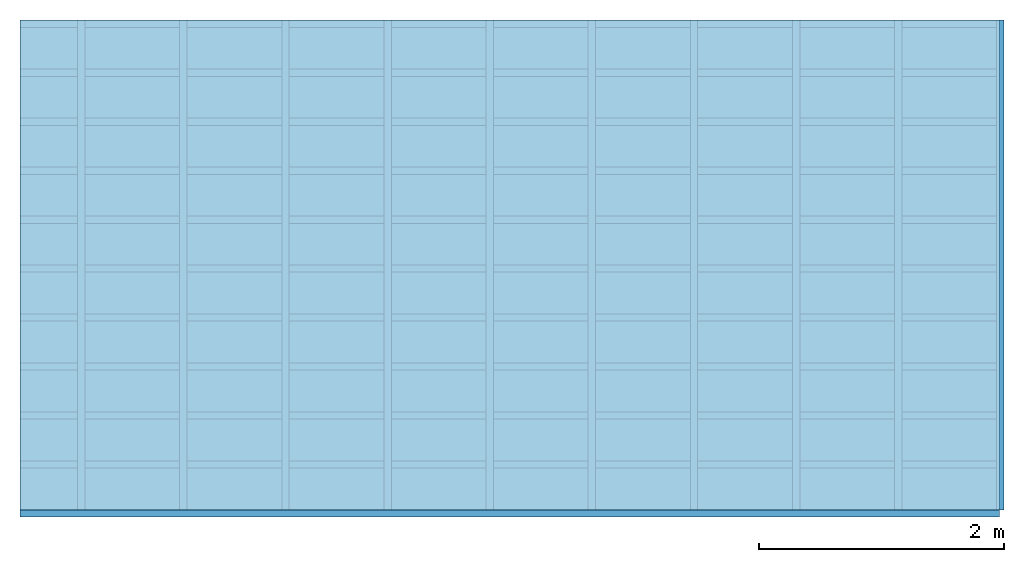
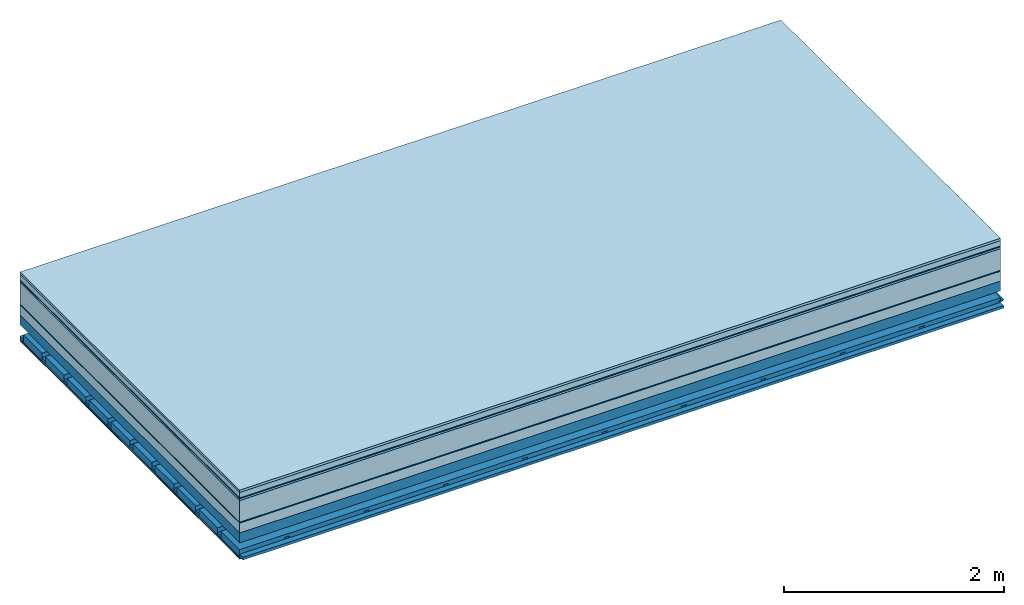
# One storey: 10 plates, 4 members, 1 element without a shape of its own.
"""IFC4 building model written with IfcOpenShell, lengths in metres."""

from ifc_helpers import new_model, si_unit, derived_unit, direction, frame, frame_2d, origin, origin_with_axes, place, context, project, spatial, polyline, rectangle, outline, extrude, material, layer, layer_set, type_object, element, aggregate, save


model = new_model("IFC4")

# Units and contexts
plan_context = context("Plan", 3, precision=1e-05, world=origin(), true_north=direction((0.0, 1.0)))
model_context = context("Model", 3, precision=1e-05, world=origin(), true_north=direction((0.0, 1.0)))
ifc_project = project(units=[si_unit("LENGTHUNIT", "METRE"), derived_unit("SOUNDPRESSUREUNIT", [(si_unit("PRESSUREUNIT", "PASCAL", prefix="MICRO"), 0)]), si_unit("ENERGYUNIT", "JOULE", prefix="MEGA"), si_unit("MASSUNIT", "GRAM", prefix="KILO"), derived_unit("THERMALTRANSMITTANCEUNIT", [(si_unit("POWERUNIT", "WATT"), 1), (si_unit("AREAUNIT", "SQUARE_METRE"), -1), (si_unit("THERMODYNAMICTEMPERATUREUNIT", "KELVIN"), -1)]), derived_unit("AREADENSITYUNIT", [(si_unit("MASSUNIT", "GRAM", prefix="KILO"), 1), (si_unit("AREAUNIT", "SQUARE_METRE"), -1)]), derived_unit("USERDEFINED", [(si_unit("ENERGYUNIT", "JOULE", prefix="MEGA"), 1), (si_unit("AREAUNIT", "SQUARE_METRE"), -1)])], contexts=[plan_context, model_context])

# Site, building, storey
site = spatial("IfcSite", under=ifc_project)
building_placement = place(None, origin())
building = spatial("IfcBuilding", under=site, at=building_placement)
storey_placement = place(building_placement, origin())
storey = spatial("IfcBuildingStorey", under=building, at=storey_placement)

# Slab, members, plates
ifc_material_1 = material(Category="07.009")
ifc_layer_1 = layer(ifc_material_1, 0.026, Name="Use and protection layer 3")
ifc_material_2 = material(Category="07.011")
ifc_layer_2 = layer(ifc_material_2, 0.06, Name="Use and protection layer 2")
ifc_material_3 = material(Name="Protective layer + Fire protection cover RF1", Category="09.007")
ifc_layer_3 = layer(ifc_material_3, 0.01, Name="Use and protection layer 1")
ifc_material_4 = material(Name="Bituminous", Category="09.003")
ifc_layer_4 = layer(ifc_material_4, 0.02, Name="Seal")
ifc_material_5 = material(Name="Mineral wool", Category="10.008")
ifc_layer_5 = layer(ifc_material_5, 0.24, Name="Exterior insulation layer 1")
ifc_material_6 = material(Name="Vapor-permeable barrier", Category="09.006")
ifc_layer_6 = layer(ifc_material_6, 0.01, Name="layer / temporary roof")
ifc_material_7 = material(Category="01.002")
ifc_layer_7 = layer(ifc_material_7, 0.11, Name="above 1st layer")
ifc_material_8 = material(Name="Rigid, of the art")
ifc_layer_8 = layer(ifc_material_8, 0.0, Name="Bond")
ifc_layer_9 = layer(None, 0.11, Name="Support")
ifc_material_9 = material(Name="no composite action")
ifc_layer_10 = layer(ifc_material_9, 0.0, Name="Bond")
ifc_layer_11 = layer(None, 0.125, Name="Coupling")
ifc_layer_12 = layer(None, 0.03, Name="Battens / profiles")
ifc_material_10 = material(Name="Plasterboard type A", Category="03.008")
ifc_layer_13 = layer(ifc_material_10, 0.0125, Name="Covering below 1st layer")
ifc_layer_14 = layer(ifc_material_10, 0.0125, Name="Covering below 2nd layer")
ifc_material_11 = material(Category="04.001")
ifc_layer_15 = layer(ifc_material_11, 0.003, Name="Surface below")
ifc_layer_set = layer_set([ifc_layer_1, ifc_layer_2, ifc_layer_3, ifc_layer_4, ifc_layer_5, ifc_layer_6, ifc_layer_7, ifc_layer_8, ifc_layer_9, ifc_layer_10, ifc_layer_11, ifc_layer_12, ifc_layer_13, ifc_layer_14, ifc_layer_15])
slab_type = type_object("IfcSlabType", Name="F0090", PredefinedType="NOTDEFINED", material=ifc_layer_set)
slab_placement = place(None, frame((0.0, 0.0, 0.0), z_axis=(0.0, 0.0, -1.0), x_axis=(1.0, 0.0, 0.0)))
slab = element("IfcSlab", 1, at=slab_placement, inside=storey, type_object=slab_type, material=ifc_layer_set, Name="Slab #1")
ifc_material_12 = material(Name="Solid timber panel")
member_1_placement = place(slab_placement, origin())
member_1 = element("IfcMember", 2, at=member_1_placement, material=ifc_material_12, Name="Support", context=plan_context, shape_type="SweptSolid", body=[
    extrude(rectangle(XDim=1.0, YDim=0.11, at=frame_2d((0.5, 0.055), x_axis=(1.0, 0.0))), frame((0.0, 4.0, 0.476), z_axis=(0.0, -1.0, 0.0), x_axis=(1.0, 0.0, 0.0)), (0.0, 0.0, 1.0), 4.0),
    extrude(rectangle(XDim=1.0, YDim=0.11, at=frame_2d((0.5, 0.055), x_axis=(1.0, 0.0))), frame((1.0, 4.0, 0.476), z_axis=(0.0, -1.0, 0.0), x_axis=(1.0, 0.0, 0.0)), (0.0, 0.0, 1.0), 4.0),
    extrude(rectangle(XDim=1.0, YDim=0.11, at=frame_2d((0.5, 0.055), x_axis=(1.0, 0.0))), frame((2.0, 4.0, 0.476), z_axis=(0.0, -1.0, 0.0), x_axis=(1.0, 0.0, 0.0)), (0.0, 0.0, 1.0), 4.0),
    extrude(rectangle(XDim=1.0, YDim=0.11, at=frame_2d((0.5, 0.055), x_axis=(1.0, 0.0))), frame((3.0, 4.0, 0.476), z_axis=(0.0, -1.0, 0.0), x_axis=(1.0, 0.0, 0.0)), (0.0, 0.0, 1.0), 4.0),
    extrude(rectangle(XDim=1.0, YDim=0.11, at=frame_2d((0.5, 0.055), x_axis=(1.0, 0.0))), frame((4.0, 4.0, 0.476), z_axis=(0.0, -1.0, 0.0), x_axis=(1.0, 0.0, 0.0)), (0.0, 0.0, 1.0), 4.0),
    extrude(rectangle(XDim=1.0, YDim=0.11, at=frame_2d((0.5, 0.055), x_axis=(1.0, 0.0))), frame((5.0, 4.0, 0.476), z_axis=(0.0, -1.0, 0.0), x_axis=(1.0, 0.0, 0.0)), (0.0, 0.0, 1.0), 4.0),
    extrude(rectangle(XDim=1.0, YDim=0.11, at=frame_2d((0.5, 0.055), x_axis=(1.0, 0.0))), frame((6.0, 4.0, 0.476), z_axis=(0.0, -1.0, 0.0), x_axis=(1.0, 0.0, 0.0)), (0.0, 0.0, 1.0), 4.0),
    extrude(rectangle(XDim=1.0, YDim=0.11, at=frame_2d((0.5, 0.055), x_axis=(1.0, 0.0))), frame((7.0, 4.0, 0.476), z_axis=(0.0, -1.0, 0.0), x_axis=(1.0, 0.0, 0.0)), (0.0, 0.0, 1.0), 4.0),
])
ifc_material_13 = material()
member_2_placement = place(slab_placement, origin())
member_2 = element("IfcMember", 3, at=member_2_placement, material=ifc_material_13, Name="Coupling", context=plan_context, shape_type="SweptSolid", body=[
    extrude(outline(polyline([(0.0, 0.0), (0.06, 0.0), (0.04, 0.02), (0.02, 0.02), (0.0, 0.0)])), frame((0.47, 4.0, 0.691), z_axis=(0.0, -1.0, 0.0), x_axis=(1.0, 0.0, 0.0)), (0.0, 0.0, 1.0), 4.0),
    extrude(outline(polyline([(0.0, 0.0), (0.06, 0.0), (0.04, 0.02), (0.02, 0.02), (0.0, 0.0)])), frame((1.304, 4.0, 0.691), z_axis=(0.0, -1.0, 0.0), x_axis=(1.0, 0.0, 0.0)), (0.0, 0.0, 1.0), 4.0),
    extrude(outline(polyline([(0.0, 0.0), (0.06, 0.0), (0.04, 0.02), (0.02, 0.02), (0.0, 0.0)])), frame((2.138, 4.0, 0.691), z_axis=(0.0, -1.0, 0.0), x_axis=(1.0, 0.0, 0.0)), (0.0, 0.0, 1.0), 4.0),
    extrude(outline(polyline([(0.0, 0.0), (0.06, 0.0), (0.04, 0.02), (0.02, 0.02), (0.0, 0.0)])), frame((2.972, 4.0, 0.691), z_axis=(0.0, -1.0, 0.0), x_axis=(1.0, 0.0, 0.0)), (0.0, 0.0, 1.0), 4.0),
    extrude(outline(polyline([(0.0, 0.0), (0.06, 0.0), (0.04, 0.02), (0.02, 0.02), (0.0, 0.0)])), frame((3.806, 4.0, 0.691), z_axis=(0.0, -1.0, 0.0), x_axis=(1.0, 0.0, 0.0)), (0.0, 0.0, 1.0), 4.0),
    extrude(outline(polyline([(0.0, 0.0), (0.06, 0.0), (0.04, 0.02), (0.02, 0.02), (0.0, 0.0)])), frame((4.64, 4.0, 0.691), z_axis=(0.0, -1.0, 0.0), x_axis=(1.0, 0.0, 0.0)), (0.0, 0.0, 1.0), 4.0),
    extrude(outline(polyline([(0.0, 0.0), (0.06, 0.0), (0.04, 0.02), (0.02, 0.02), (0.0, 0.0)])), frame((5.474, 4.0, 0.691), z_axis=(0.0, -1.0, 0.0), x_axis=(1.0, 0.0, 0.0)), (0.0, 0.0, 1.0), 4.0),
    extrude(outline(polyline([(0.0, 0.0), (0.06, 0.0), (0.04, 0.02), (0.02, 0.02), (0.0, 0.0)])), frame((6.308, 4.0, 0.691), z_axis=(0.0, -1.0, 0.0), x_axis=(1.0, 0.0, 0.0)), (0.0, 0.0, 1.0), 4.0),
    extrude(outline(polyline([(0.0, 0.0), (0.06, 0.0), (0.04, 0.02), (0.02, 0.02), (0.0, 0.0)])), frame((7.142, 4.0, 0.691), z_axis=(0.0, -1.0, 0.0), x_axis=(1.0, 0.0, 0.0)), (0.0, 0.0, 1.0), 4.0),
    extrude(outline(polyline([(0.0, 0.0), (0.06, 0.0), (0.04, 0.02), (0.02, 0.02), (0.0, 0.0)])), frame((7.976, 4.0, 0.691), z_axis=(0.0, -1.0, 0.0), x_axis=(1.0, 0.0, 0.0)), (0.0, 0.0, 1.0), 4.0),
])
member_3_placement = place(slab_placement, origin())
member_3 = element("IfcMember", 4, at=member_3_placement, material=ifc_material_13, Name="Battens / profiles", context=plan_context, shape_type="SweptSolid", body=[
    extrude(rectangle(XDim=0.06, YDim=0.03, at=frame_2d((0.03, 0.015), x_axis=(1.0, 0.0))), frame((0.0, 0.0, 0.711), z_axis=(1.0, 0.0, 0.0), x_axis=(0.0, 1.0, 0.0)), (0.0, 0.0, 1.0), 8.0),
    extrude(rectangle(XDim=0.06, YDim=0.03, at=frame_2d((0.03, 0.015), x_axis=(1.0, 0.0))), frame((0.0, 0.4, 0.711), z_axis=(1.0, 0.0, 0.0), x_axis=(0.0, 1.0, 0.0)), (0.0, 0.0, 1.0), 8.0),
    extrude(rectangle(XDim=0.06, YDim=0.03, at=frame_2d((0.03, 0.015), x_axis=(1.0, 0.0))), frame((0.0, 0.8, 0.711), z_axis=(1.0, 0.0, 0.0), x_axis=(0.0, 1.0, 0.0)), (0.0, 0.0, 1.0), 8.0),
    extrude(rectangle(XDim=0.06, YDim=0.03, at=frame_2d((0.03, 0.015), x_axis=(1.0, 0.0))), frame((0.0, 1.2, 0.711), z_axis=(1.0, 0.0, 0.0), x_axis=(0.0, 1.0, 0.0)), (0.0, 0.0, 1.0), 8.0),
    extrude(rectangle(XDim=0.06, YDim=0.03, at=frame_2d((0.03, 0.015), x_axis=(1.0, 0.0))), frame((0.0, 1.6, 0.711), z_axis=(1.0, 0.0, 0.0), x_axis=(0.0, 1.0, 0.0)), (0.0, 0.0, 1.0), 8.0),
    extrude(rectangle(XDim=0.06, YDim=0.03, at=frame_2d((0.03, 0.015), x_axis=(1.0, 0.0))), frame((0.0, 2.0, 0.711), z_axis=(1.0, 0.0, 0.0), x_axis=(0.0, 1.0, 0.0)), (0.0, 0.0, 1.0), 8.0),
    extrude(rectangle(XDim=0.06, YDim=0.03, at=frame_2d((0.03, 0.015), x_axis=(1.0, 0.0))), frame((0.0, 2.4, 0.711), z_axis=(1.0, 0.0, 0.0), x_axis=(0.0, 1.0, 0.0)), (0.0, 0.0, 1.0), 8.0),
    extrude(rectangle(XDim=0.06, YDim=0.03, at=frame_2d((0.03, 0.015), x_axis=(1.0, 0.0))), frame((0.0, 2.8, 0.711), z_axis=(1.0, 0.0, 0.0), x_axis=(0.0, 1.0, 0.0)), (0.0, 0.0, 1.0), 8.0),
    extrude(rectangle(XDim=0.06, YDim=0.03, at=frame_2d((0.03, 0.015), x_axis=(1.0, 0.0))), frame((0.0, 3.2, 0.711), z_axis=(1.0, 0.0, 0.0), x_axis=(0.0, 1.0, 0.0)), (0.0, 0.0, 1.0), 8.0),
    extrude(rectangle(XDim=0.06, YDim=0.03, at=frame_2d((0.03, 0.015), x_axis=(1.0, 0.0))), frame((0.0, 3.6, 0.711), z_axis=(1.0, 0.0, 0.0), x_axis=(0.0, 1.0, 0.0)), (0.0, 0.0, 1.0), 8.0),
    extrude(rectangle(XDim=0.06, YDim=0.03, at=frame_2d((0.03, 0.015), x_axis=(1.0, 0.0))), frame((0.0, 4.0, 0.711), z_axis=(1.0, 0.0, 0.0), x_axis=(0.0, 1.0, 0.0)), (0.0, 0.0, 1.0), 8.0),
])
ifc_material_14 = material()
member_4_placement = place(slab_placement, origin())
member_4 = element("IfcMember", 5, at=member_4_placement, material=ifc_material_14, Name="Cavity", context=plan_context, shape_type="SweptSolid", body=[
    extrude(rectangle(XDim=0.34, YDim=0.08, at=frame_2d((0.17, 0.04), x_axis=(1.0, 0.0))), frame((0.0, 0.06, 0.661), z_axis=(1.0, 0.0, 0.0), x_axis=(0.0, 1.0, 0.0)), (0.0, 0.0, 1.0), 8.0),
    extrude(rectangle(XDim=0.34, YDim=0.08, at=frame_2d((0.17, 0.04), x_axis=(1.0, 0.0))), frame((0.0, 0.46, 0.661), z_axis=(1.0, 0.0, 0.0), x_axis=(0.0, 1.0, 0.0)), (0.0, 0.0, 1.0), 8.0),
    extrude(rectangle(XDim=0.34, YDim=0.08, at=frame_2d((0.17, 0.04), x_axis=(1.0, 0.0))), frame((0.0, 0.86, 0.661), z_axis=(1.0, 0.0, 0.0), x_axis=(0.0, 1.0, 0.0)), (0.0, 0.0, 1.0), 8.0),
    extrude(rectangle(XDim=0.34, YDim=0.08, at=frame_2d((0.17, 0.04), x_axis=(1.0, 0.0))), frame((0.0, 1.26, 0.661), z_axis=(1.0, 0.0, 0.0), x_axis=(0.0, 1.0, 0.0)), (0.0, 0.0, 1.0), 8.0),
    extrude(rectangle(XDim=0.34, YDim=0.08, at=frame_2d((0.17, 0.04), x_axis=(1.0, 0.0))), frame((0.0, 1.66, 0.661), z_axis=(1.0, 0.0, 0.0), x_axis=(0.0, 1.0, 0.0)), (0.0, 0.0, 1.0), 8.0),
    extrude(rectangle(XDim=0.34, YDim=0.08, at=frame_2d((0.17, 0.04), x_axis=(1.0, 0.0))), frame((0.0, 2.06, 0.661), z_axis=(1.0, 0.0, 0.0), x_axis=(0.0, 1.0, 0.0)), (0.0, 0.0, 1.0), 8.0),
    extrude(rectangle(XDim=0.34, YDim=0.08, at=frame_2d((0.17, 0.04), x_axis=(1.0, 0.0))), frame((0.0, 2.46, 0.661), z_axis=(1.0, 0.0, 0.0), x_axis=(0.0, 1.0, 0.0)), (0.0, 0.0, 1.0), 8.0),
    extrude(rectangle(XDim=0.34, YDim=0.08, at=frame_2d((0.17, 0.04), x_axis=(1.0, 0.0))), frame((0.0, 2.86, 0.661), z_axis=(1.0, 0.0, 0.0), x_axis=(0.0, 1.0, 0.0)), (0.0, 0.0, 1.0), 8.0),
    extrude(rectangle(XDim=0.34, YDim=0.08, at=frame_2d((0.17, 0.04), x_axis=(1.0, 0.0))), frame((0.0, 3.26, 0.661), z_axis=(1.0, 0.0, 0.0), x_axis=(0.0, 1.0, 0.0)), (0.0, 0.0, 1.0), 8.0),
    extrude(rectangle(XDim=0.34, YDim=0.08, at=frame_2d((0.17, 0.04), x_axis=(1.0, 0.0))), frame((0.0, 3.66, 0.661), z_axis=(1.0, 0.0, 0.0), x_axis=(0.0, 1.0, 0.0)), (0.0, 0.0, 1.0), 8.0),
])
plate_1_placement = place(slab_placement, origin())
plate_1 = element("IfcPlate", 6, at=plate_1_placement, material=ifc_material_1, Name="Use and protection layer 3", context=plan_context, shape_type="SweptSolid", body=[
    extrude(rectangle(XDim=8.0, YDim=4.0, at=frame_2d((4.0, 2.0), x_axis=(1.0, 0.0))), origin_with_axes(), (0.0, 0.0, 1.0), 0.026),
])
plate_2_placement = place(slab_placement, origin())
plate_2 = element("IfcPlate", 7, at=plate_2_placement, material=ifc_material_2, Name="Use and protection layer 2", context=plan_context, shape_type="SweptSolid", body=[
    extrude(rectangle(XDim=8.0, YDim=4.0, at=frame_2d((4.0, 2.0), x_axis=(1.0, 0.0))), frame((0.0, 0.0, 0.026), z_axis=(0.0, 0.0, 1.0), x_axis=(1.0, 0.0, 0.0)), (0.0, 0.0, 1.0), 0.06),
])
plate_3_placement = place(slab_placement, origin())
plate_3 = element("IfcPlate", 8, at=plate_3_placement, material=ifc_material_3, Name="Use and protection layer 1", context=plan_context, shape_type="SweptSolid", body=[
    extrude(rectangle(XDim=8.0, YDim=4.0, at=frame_2d((4.0, 2.0), x_axis=(1.0, 0.0))), frame((0.0, 0.0, 0.086), z_axis=(0.0, 0.0, 1.0), x_axis=(1.0, 0.0, 0.0)), (0.0, 0.0, 1.0), 0.01),
])
plate_4_placement = place(slab_placement, origin())
plate_4 = element("IfcPlate", 9, at=plate_4_placement, material=ifc_material_4, Name="Seal", context=plan_context, shape_type="SweptSolid", body=[
    extrude(rectangle(XDim=8.0, YDim=4.0, at=frame_2d((4.0, 2.0), x_axis=(1.0, 0.0))), frame((0.0, 0.0, 0.096), z_axis=(0.0, 0.0, 1.0), x_axis=(1.0, 0.0, 0.0)), (0.0, 0.0, 1.0), 0.02),
])
plate_5_placement = place(slab_placement, origin())
plate_5 = element("IfcPlate", 10, at=plate_5_placement, material=ifc_material_5, Name="Exterior insulation layer 1", context=plan_context, shape_type="SweptSolid", body=[
    extrude(rectangle(XDim=8.0, YDim=4.0, at=frame_2d((4.0, 2.0), x_axis=(1.0, 0.0))), frame((0.0, 0.0, 0.116), z_axis=(0.0, 0.0, 1.0), x_axis=(1.0, 0.0, 0.0)), (0.0, 0.0, 1.0), 0.24),
])
plate_6_placement = place(slab_placement, origin())
plate_6 = element("IfcPlate", 11, at=plate_6_placement, material=ifc_material_6, Name="layer / temporary roof", context=plan_context, shape_type="SweptSolid", body=[
    extrude(rectangle(XDim=8.0, YDim=4.0, at=frame_2d((4.0, 2.0), x_axis=(1.0, 0.0))), frame((0.0, 0.0, 0.356), z_axis=(0.0, 0.0, 1.0), x_axis=(1.0, 0.0, 0.0)), (0.0, 0.0, 1.0), 0.01),
])
plate_7_placement = place(slab_placement, origin())
plate_7 = element("IfcPlate", 12, at=plate_7_placement, material=ifc_material_7, Name="above 1st layer", context=plan_context, shape_type="SweptSolid", body=[
    extrude(rectangle(XDim=8.0, YDim=4.0, at=frame_2d((4.0, 2.0), x_axis=(1.0, 0.0))), frame((0.0, 0.0, 0.366), z_axis=(0.0, 0.0, 1.0), x_axis=(1.0, 0.0, 0.0)), (0.0, 0.0, 1.0), 0.11),
])
plate_8_placement = place(slab_placement, origin())
plate_8 = element("IfcPlate", 13, at=plate_8_placement, material=ifc_material_10, Name="Covering below 1st layer", context=plan_context, shape_type="SweptSolid", body=[
    extrude(rectangle(XDim=8.0, YDim=4.0, at=frame_2d((4.0, 2.0), x_axis=(1.0, 0.0))), frame((0.0, 0.0, 0.741), z_axis=(0.0, 0.0, 1.0), x_axis=(1.0, 0.0, 0.0)), (0.0, 0.0, 1.0), 0.0125),
])
plate_9_placement = place(slab_placement, origin())
plate_9 = element("IfcPlate", 14, at=plate_9_placement, material=ifc_material_10, Name="Covering below 2nd layer", context=plan_context, shape_type="SweptSolid", body=[
    extrude(rectangle(XDim=8.0, YDim=4.0, at=frame_2d((4.0, 2.0), x_axis=(1.0, 0.0))), frame((0.0, 0.0, 0.7535), z_axis=(0.0, 0.0, 1.0), x_axis=(1.0, 0.0, 0.0)), (0.0, 0.0, 1.0), 0.0125),
])
plate_10_placement = place(slab_placement, origin())
plate_10 = element("IfcPlate", 15, at=plate_10_placement, material=ifc_material_11, Name="Surface below", context=plan_context, shape_type="SweptSolid", body=[
    extrude(rectangle(XDim=8.0, YDim=4.0, at=frame_2d((4.0, 2.0), x_axis=(1.0, 0.0))), frame((0.0, 0.0, 0.766), z_axis=(0.0, 0.0, 1.0), x_axis=(1.0, 0.0, 0.0)), (0.0, 0.0, 1.0), 0.003),
])
aggregate(slab, [plate_1, plate_2, plate_3, plate_4, plate_5, plate_6, plate_7, member_1, member_2, member_3, member_4, plate_8, plate_9, plate_10])

save(model, "model.ifc")
